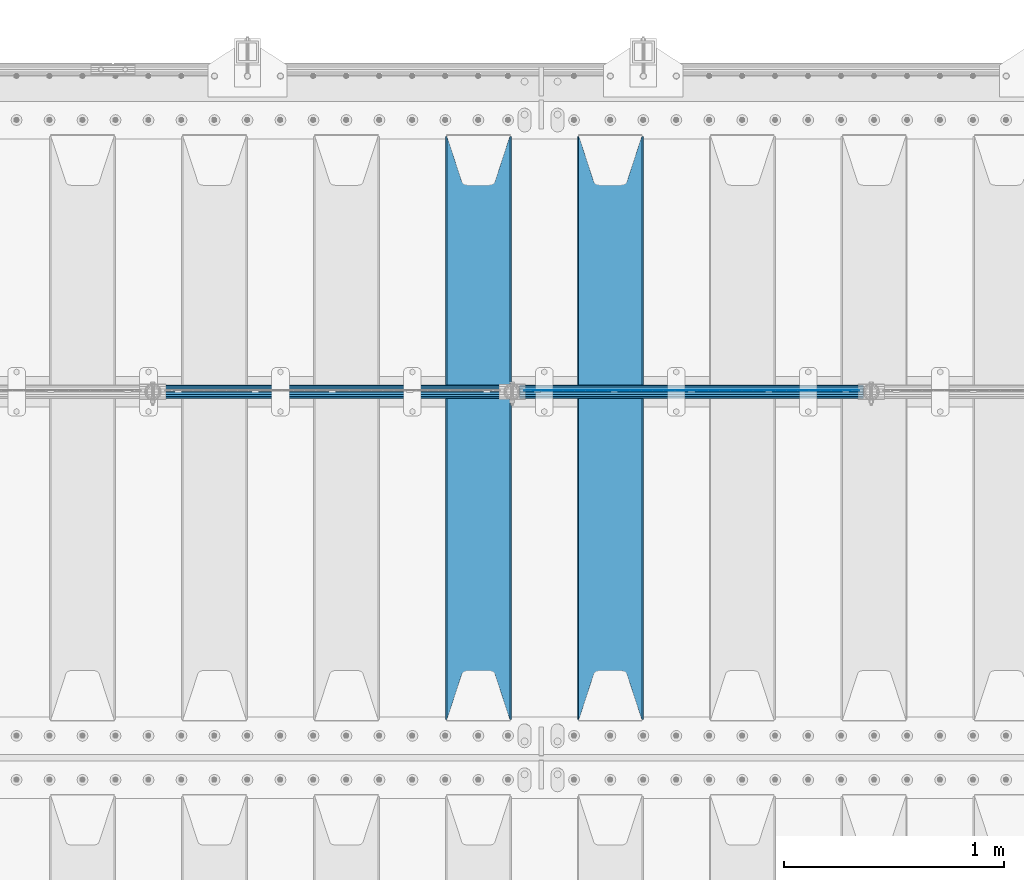
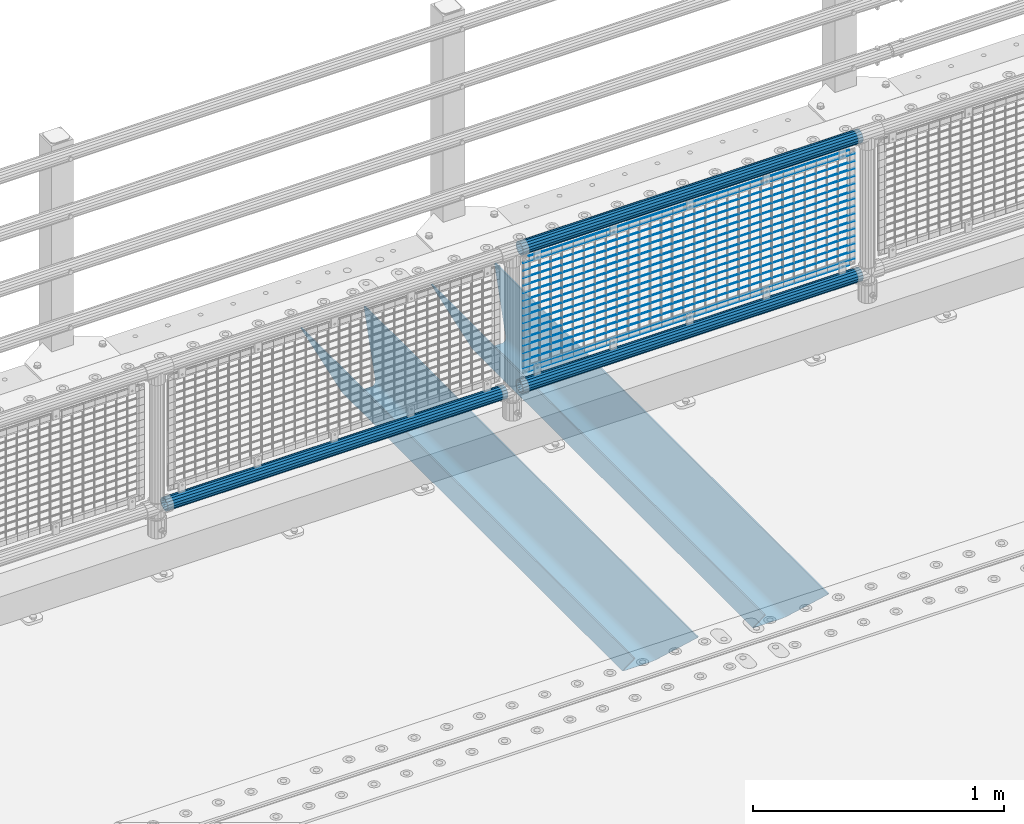
# One storey, part 132 of 270: 22 beams.
"""IFC2X3 building model written with IfcOpenShell, lengths in millimetres."""

from ifc_helpers import new_model, si_unit, frame, origin_with_axes, place, context, subcontext, project, spatial, faceted_brep, material, type_object, element, save


model = new_model("IFC2X3")

# Units and contexts
model_context = context("Model", 3, precision=1e-05, world=origin_with_axes())
body_context = subcontext(model_context, "Body", "Model", "MODEL_VIEW")
ifc_project = project(units=[si_unit("LENGTHUNIT", "METRE", prefix="MILLI"), si_unit("AREAUNIT", "SQUARE_METRE"), si_unit("VOLUMEUNIT", "CUBIC_METRE"), si_unit("MASSUNIT", "GRAM", prefix="KILO"), si_unit("TIMEUNIT", "SECOND"), si_unit("PLANEANGLEUNIT", "RADIAN"), si_unit("SOLIDANGLEUNIT", "STERADIAN"), si_unit("THERMODYNAMICTEMPERATUREUNIT", "DEGREE_CELSIUS"), si_unit("LUMINOUSINTENSITYUNIT", "LUMEN")], contexts=[model_context])

# Site, building, storey
site_placement = place(None, origin_with_axes())
site = spatial("IfcSite", under=ifc_project, at=site_placement, CompositionType="ELEMENT")
building_placement = place(site_placement, origin_with_axes())
building = spatial("IfcBuilding", under=site, at=building_placement, Name="Standard", CompositionType="ELEMENT")
storey_placement = place(building_placement, origin_with_axes())
storey = spatial("IfcBuildingStorey", under=building, at=storey_placement, Name="Undefined", CompositionType="ELEMENT", Elevation=0.0)

# Beams
ifc_material_1 = material(Name="STEEL/S355N")
beam_type_1 = type_object("IfcBeamType", PredefinedType="NOTDEFINED")
beam_1_placement = place(storey_placement, frame((7600.0, -17825.0, -115.0), z_axis=(0.0, 0.0, 1.0), x_axis=(0.0, 1.0, 0.0)))
element("IfcBeam", 1, at=beam_1_placement, inside=storey, type_object=beam_type_1, material=ifc_material_1, context=body_context, shape_type="Brep", body=[
    faceted_brep([(0.0, 150.0, 115.0), (0.0, 143.689999999999, 115.0), (2650.00000000297, 143.689999999999, 115.0), (2650.00000000297, 150.0, 115.0), (2650.00000000297, 142.059565218398, 110.000000003096), (2650.00000000297, 148.3695652184, 110.000000003096), (2441.90079219209, -80.1103600731112, -98.0992078077845), (2437.7588105432, -77.5672621345584, -102.241189456673), (2434.06523489747, -74.4080125315522, -105.934765102404), (2430.9108609509, -70.710272125576, -109.089139048974), (2428.37322971128, -66.5649389910068, -111.626770288588), (2426.51472138055, -62.0739139532889, -113.485278619323), (2425.38102192092, -57.3475956567672, -114.618978078955), (2424.99999999987, -52.5021667386536, -115.0), (2424.99999999987, 52.5021667386536, -115.0), (2425.38102192092, 57.3475956567672, -114.618978078955), (2426.51472138055, 62.0739139532889, -113.485278619323), (2428.37322971128, 66.5649389910068, -111.626770288588), (2430.9108609509, 70.710272125576, -109.089139048974), (2434.06523489747, 74.4080125315522, -105.934765102404), (2437.7588105432, 77.5672621345584, -102.241189456673), (2441.90079219209, 80.1103600731112, -98.0992078077846), (2446.38936140511, 81.9747917625791, -93.6106385947584), (2448.2494850041, 76.2713538057251, -91.7505149957729), (2444.62967112263, 74.76777986261, -95.3703288772456), (2441.28936334126, 72.7168944282894, -98.710636658607), (2438.31067330439, 70.1691124903846, -101.689326695487), (2435.76682334747, 67.1870637758839, -104.233176652398), (2433.72034654133, 63.8440531834895, -106.279653458539), (2432.22154950042, 60.222258798236, -107.778450499454), (2431.30727574265, 56.4107117849089, -108.692724257221), (2430.99999999987, 52.5031078186876, -109.0), (2430.99999999987, -52.5031078186876, -109.0), (2431.30727574265, -56.4107117849089, -108.692724257221), (2432.22154950042, -60.222258798236, -107.778450499454), (2433.72034654133, -63.8440531834895, -106.279653458539), (2435.76682334747, -67.1870637758839, -104.233176652398), (2438.31067330438, -70.1691124903846, -101.689326695487), (2441.28936334126, -72.7168944282894, -98.7106366586071), (2444.62967112263, -74.76777986261, -95.3703288772457), (2448.2494850041, -76.2713538057251, -91.7505149957729), (2650.00000000297, -142.059565218398, 110.000000003096), (2650.00000000297, -148.3695652184, 110.000000003096), (2446.38936140511, -81.9747917625791, -93.6106385947584), (2650.00000000297, -143.689999999999, 115.0), (2650.00000000297, -150.0, 115.0), (0.0, -143.689999999999, 115.0), (0.0, -150.0, 115.0), (0.0, -148.369565218261, 110.000000002672), (203.610638597431, -81.9747917625791, -93.6106385947584), (208.099207810457, -80.1103600731112, -98.0992078077845), (212.241189459342, -77.5672621345584, -102.241189456673), (215.934765105078, -74.4080125315522, -105.934765102404), (219.089139051644, -70.710272125576, -109.089139048974), (221.626770291259, -66.5649389910068, -111.626770288588), (223.485278621993, -62.0739139532889, -113.485278619323), (224.618978081628, -57.3475956567672, -114.618978078955), (225.00000000267, -52.5021667386536, -115.0), (225.00000000267, 52.5021667386536, -115.0), (224.618978081628, 57.3475956567672, -114.618978078955), (223.485278621993, 62.0739139532889, -113.485278619323), (221.626770291259, 66.5649389910068, -111.626770288588), (219.089139051644, 70.710272125576, -109.089139048974), (215.934765105078, 74.4080125315522, -105.934765102404), (212.241189459342, 77.5672621345584, -102.241189456673), (208.099207810457, 80.1103600731112, -98.0992078077846), (203.610638597431, 81.9747917625791, -93.6106385947584), (0.0, 148.369565218261, 110.000000002672), (0.0, 142.05956521826, 110.000000002672), (201.750514998446, 76.2713538057251, -91.7505149957729), (205.370328879915, 74.76777986261, -95.3703288772456), (208.710636661279, 72.7168944282894, -98.710636658607), (211.689326698157, 70.1691124903846, -101.689326695487), (214.233176655071, 67.1870637758839, -104.233176652398), (216.27965346121, 63.8440531834895, -106.279653458539), (217.778450502126, 60.222258798236, -107.778450499454), (218.692724259894, 56.4107117849089, -108.692724257221), (219.00000000267, 52.5031078186876, -109.0), (219.00000000267, -52.5031078186876, -109.0), (218.692724259894, -56.4107117849089, -108.692724257221), (217.778450502123, -60.222258798236, -107.778450499454), (216.27965346121, -63.8440531834895, -106.279653458539), (214.233176655071, -67.1870637758839, -104.233176652398), (211.689326698157, -70.1691124903846, -101.689326695487), (208.710636661279, -72.7168944282894, -98.7106366586071), (205.370328879915, -74.76777986261, -95.3703288772457), (201.750514998446, -76.2713538057251, -91.7505149957729), (0.0, -142.05956521826, 110.000000002672)], [[[0, 1, 2, 3]], [[3, 2, 4, 5]], [[6, 7, 8, 9, 10, 11, 12, 13, 14, 15, 16, 17, 18, 19, 20, 21, 22, 5, 4, 23, 24, 25, 26, 27, 28, 29, 30, 31, 32, 33, 34, 35, 36, 37, 38, 39, 40, 41, 42, 43]], [[44, 45, 42, 41]], [[46, 47, 45, 44]], [[43, 42, 45, 47, 48, 49]], [[6, 43, 49, 50]], [[7, 6, 50, 51]], [[8, 7, 51, 52]], [[9, 8, 52, 53]], [[10, 9, 53, 54]], [[11, 10, 54, 55]], [[12, 11, 55, 56]], [[13, 12, 56, 57]], [[14, 13, 57, 58]], [[15, 14, 58, 59]], [[16, 15, 59, 60]], [[17, 16, 60, 61]], [[18, 17, 61, 62]], [[19, 18, 62, 63]], [[20, 19, 63, 64]], [[21, 20, 64, 65]], [[22, 21, 65, 66]], [[0, 3, 5, 22, 66, 67]], [[1, 0, 67, 68]], [[23, 4, 2, 1, 68, 69]], [[24, 23, 69, 70]], [[25, 24, 70, 71]], [[26, 25, 71, 72]], [[27, 26, 72, 73]], [[28, 27, 73, 74]], [[29, 28, 74, 75]], [[30, 29, 75, 76]], [[31, 30, 76, 77]], [[32, 31, 77, 78]], [[33, 32, 78, 79]], [[34, 33, 79, 80]], [[35, 34, 80, 81]], [[36, 35, 81, 82]], [[37, 36, 82, 83]], [[38, 37, 83, 84]], [[39, 38, 84, 85]], [[40, 39, 85, 86]], [[46, 44, 41, 40, 86, 87]], [[47, 46, 87, 48]], [[86, 85, 84, 83, 82, 81, 80, 79, 78, 77, 76, 75, 74, 73, 72, 71, 70, 69, 68, 67, 66, 65, 64, 63, 62, 61, 60, 59, 58, 57, 56, 55, 54, 53, 52, 51, 50, 49, 48, 87]]]),
])
beam_2_placement = place(storey_placement, frame((7000.0, -17825.0, -115.0), z_axis=(0.0, 0.0, 1.0), x_axis=(0.0, 1.0, 0.0)))
element("IfcBeam", 2, at=beam_2_placement, inside=storey, type_object=beam_type_1, material=ifc_material_1, context=body_context, shape_type="Brep", body=[
    faceted_brep([(0.0, 150.0, 115.0), (0.0, 143.689999999999, 115.0), (2650.00000000297, 143.689999999999, 115.0), (2650.00000000297, 150.0, 115.0), (2650.00000000297, 142.059565218398, 110.000000003096), (2650.00000000297, 148.3695652184, 110.000000003096), (2441.90079219209, -80.1103600731112, -98.0992078077845), (2437.7588105432, -77.5672621345584, -102.241189456673), (2434.06523489747, -74.4080125315522, -105.934765102404), (2430.9108609509, -70.710272125576, -109.089139048974), (2428.37322971128, -66.5649389910068, -111.626770288588), (2426.51472138055, -62.0739139532889, -113.485278619323), (2425.38102192092, -57.3475956567672, -114.618978078955), (2424.99999999987, -52.5021667386536, -115.0), (2424.99999999987, 52.5021667386536, -115.0), (2425.38102192092, 57.3475956567672, -114.618978078955), (2426.51472138055, 62.0739139532889, -113.485278619323), (2428.37322971128, 66.5649389910068, -111.626770288588), (2430.9108609509, 70.710272125576, -109.089139048974), (2434.06523489747, 74.4080125315522, -105.934765102404), (2437.7588105432, 77.5672621345584, -102.241189456673), (2441.90079219209, 80.1103600731112, -98.0992078077846), (2446.38936140511, 81.9747917625791, -93.6106385947584), (2448.2494850041, 76.2713538057251, -91.7505149957729), (2444.62967112263, 74.76777986261, -95.3703288772456), (2441.28936334126, 72.7168944282894, -98.710636658607), (2438.31067330439, 70.1691124903846, -101.689326695487), (2435.76682334747, 67.1870637758839, -104.233176652398), (2433.72034654133, 63.8440531834895, -106.279653458539), (2432.22154950042, 60.222258798236, -107.778450499454), (2431.30727574265, 56.4107117849089, -108.692724257221), (2430.99999999987, 52.5031078186876, -109.0), (2430.99999999987, -52.5031078186876, -109.0), (2431.30727574265, -56.4107117849089, -108.692724257221), (2432.22154950042, -60.222258798236, -107.778450499454), (2433.72034654133, -63.8440531834895, -106.279653458539), (2435.76682334747, -67.1870637758839, -104.233176652398), (2438.31067330438, -70.1691124903846, -101.689326695487), (2441.28936334126, -72.7168944282894, -98.7106366586071), (2444.62967112263, -74.76777986261, -95.3703288772457), (2448.2494850041, -76.2713538057251, -91.7505149957729), (2650.00000000297, -142.059565218398, 110.000000003096), (2650.00000000297, -148.3695652184, 110.000000003096), (2446.38936140511, -81.9747917625791, -93.6106385947584), (2650.00000000297, -143.689999999999, 115.0), (2650.00000000297, -150.0, 115.0), (0.0, -143.689999999999, 115.0), (0.0, -150.0, 115.0), (0.0, -148.369565218261, 110.000000002672), (203.610638597431, -81.9747917625791, -93.6106385947584), (208.099207810457, -80.1103600731112, -98.0992078077845), (212.241189459342, -77.5672621345584, -102.241189456673), (215.934765105078, -74.4080125315522, -105.934765102404), (219.089139051644, -70.710272125576, -109.089139048974), (221.626770291259, -66.5649389910068, -111.626770288588), (223.485278621993, -62.0739139532889, -113.485278619323), (224.618978081628, -57.3475956567672, -114.618978078955), (225.00000000267, -52.5021667386536, -115.0), (225.00000000267, 52.5021667386536, -115.0), (224.618978081628, 57.3475956567672, -114.618978078955), (223.485278621993, 62.0739139532889, -113.485278619323), (221.626770291259, 66.5649389910068, -111.626770288588), (219.089139051644, 70.710272125576, -109.089139048974), (215.934765105078, 74.4080125315522, -105.934765102404), (212.241189459342, 77.5672621345584, -102.241189456673), (208.099207810457, 80.1103600731112, -98.0992078077846), (203.610638597431, 81.9747917625791, -93.6106385947584), (0.0, 148.369565218261, 110.000000002672), (0.0, 142.05956521826, 110.000000002672), (201.750514998446, 76.2713538057251, -91.7505149957729), (205.370328879915, 74.76777986261, -95.3703288772456), (208.710636661279, 72.7168944282894, -98.710636658607), (211.689326698157, 70.1691124903846, -101.689326695487), (214.233176655071, 67.1870637758839, -104.233176652398), (216.27965346121, 63.8440531834895, -106.279653458539), (217.778450502126, 60.222258798236, -107.778450499454), (218.692724259894, 56.4107117849089, -108.692724257221), (219.00000000267, 52.5031078186876, -109.0), (219.00000000267, -52.5031078186876, -109.0), (218.692724259894, -56.4107117849089, -108.692724257221), (217.778450502123, -60.222258798236, -107.778450499454), (216.27965346121, -63.8440531834895, -106.279653458539), (214.233176655071, -67.1870637758839, -104.233176652398), (211.689326698157, -70.1691124903846, -101.689326695487), (208.710636661279, -72.7168944282894, -98.7106366586071), (205.370328879915, -74.76777986261, -95.3703288772457), (201.750514998446, -76.2713538057251, -91.7505149957729), (0.0, -142.05956521826, 110.000000002672)], [[[0, 1, 2, 3]], [[3, 2, 4, 5]], [[6, 7, 8, 9, 10, 11, 12, 13, 14, 15, 16, 17, 18, 19, 20, 21, 22, 5, 4, 23, 24, 25, 26, 27, 28, 29, 30, 31, 32, 33, 34, 35, 36, 37, 38, 39, 40, 41, 42, 43]], [[44, 45, 42, 41]], [[46, 47, 45, 44]], [[43, 42, 45, 47, 48, 49]], [[6, 43, 49, 50]], [[7, 6, 50, 51]], [[8, 7, 51, 52]], [[9, 8, 52, 53]], [[10, 9, 53, 54]], [[11, 10, 54, 55]], [[12, 11, 55, 56]], [[13, 12, 56, 57]], [[14, 13, 57, 58]], [[15, 14, 58, 59]], [[16, 15, 59, 60]], [[17, 16, 60, 61]], [[18, 17, 61, 62]], [[19, 18, 62, 63]], [[20, 19, 63, 64]], [[21, 20, 64, 65]], [[22, 21, 65, 66]], [[0, 3, 5, 22, 66, 67]], [[1, 0, 67, 68]], [[23, 4, 2, 1, 68, 69]], [[24, 23, 69, 70]], [[25, 24, 70, 71]], [[26, 25, 71, 72]], [[27, 26, 72, 73]], [[28, 27, 73, 74]], [[29, 28, 74, 75]], [[30, 29, 75, 76]], [[31, 30, 76, 77]], [[32, 31, 77, 78]], [[33, 32, 78, 79]], [[34, 33, 79, 80]], [[35, 34, 80, 81]], [[36, 35, 81, 82]], [[37, 36, 82, 83]], [[38, 37, 83, 84]], [[39, 38, 84, 85]], [[40, 39, 85, 86]], [[46, 44, 41, 40, 86, 87]], [[47, 46, 87, 48]], [[86, 85, 84, 83, 82, 81, 80, 79, 78, 77, 76, 75, 74, 73, 72, 71, 70, 69, 68, 67, 66, 65, 64, 63, 62, 61, 60, 59, 58, 57, 56, 55, 54, 53, 52, 51, 50, 49, 48, 87]]]),
])
ifc_material_2 = material(Name="Misc_Undefined")
beam_type_2 = type_object("IfcBeamType", Name="D3", PredefinedType="NOTDEFINED")
for number, where, z_axis, x_axis in (
    (3, (7208.0, -16329.5, 851.596999999999), (0.0, 0.0, 1.0), (1.0, 0.0, 0.0)),
    (4, (7208.0, -16329.5, 669.452), (0.0, 0.0, 1.0), (1.0, 0.0, 0.0)),
    (5, (7208.0, -16329.5, 523.736), (0.0, 0.0, 1.0), (1.0, 0.0, 0.0)),
    (6, (7208.0, -16329.5, 487.307), (0.0, 0.0, 1.0), (1.0, 0.0, 0.0)),
    (7, (7208.0, -16329.5, 705.881), (0.0, 0.0, 1.0), (1.0, 0.0, 0.0)),
    (8, (7208.0, -16329.5, 596.594), (0.0, 0.0, 1.0), (1.0, 0.0, 0.0)),
    (9, (7208.0, -16329.5, 450.878), (0.0, 0.0, 1.0), (1.0, 0.0, 0.0)),
    (10, (7208.0, -16329.5, 815.167999999999), (0.0, 0.0, 1.0), (1.0, 0.0, 0.0)),
    (11, (7208.0, -16329.5, 888.025999999999), (0.0, 0.0, 1.0), (1.0, 0.0, 0.0)),
    (12, (7208.0, -16329.5, 778.738999999999), (0.0, 0.0, 1.0), (1.0, 0.0, 0.0)),
    (13, (7208.0, -16329.5, 742.309999999999), (0.0, 0.0, 1.0), (1.0, 0.0, 0.0)),
    (14, (7208.0, -16329.5, 633.023), (0.0, 0.0, 1.0), (1.0, 0.0, 0.0)),
    (15, (7208.0, -16329.5, 560.165), (0.0, 0.0, 1.0), (1.0, 0.0, 0.0)),
    (16, (7208.0, -16329.5, 414.449), (0.0, 0.0, 1.0), (1.0, 0.0, 0.0)),
):
    element("IfcBeam", number, at=place(storey_placement, frame(where, z_axis=z_axis, x_axis=x_axis)), inside=storey, type_object=beam_type_2, material=ifc_material_2, ObjectType="D3", context=body_context, shape_type="Brep", body=[
        faceted_brep([(0.0, -1.5, 0.0), (0.0, -0.75, -1.29903810567669), (1523.0, -0.75, -1.29903810567669), (1523.0, -1.5, 0.0), (0.0, 0.75, -1.29903810567669), (1523.0, 0.75, -1.29903810567669), (0.0, 1.5, 0.0), (1523.0, 1.5, 0.0), (0.0, 0.75, 1.29903810567669), (1523.0, 0.75, 1.29903810567669), (0.0, -0.75, 1.29903810567669), (1523.0, -0.75, 1.29903810567669)], [[[0, 1, 2, 3]], [[1, 4, 5, 2]], [[4, 6, 7, 5]], [[6, 8, 9, 7]], [[8, 10, 11, 9]], [[10, 0, 3, 11]], [[5, 7, 9, 11, 3, 2]], [[10, 8, 6, 4, 1, 0]]]),
    ])
beam_3_placement = place(storey_placement, frame((7233.0, -16329.5, 353.02), z_axis=(0.0, 0.0, 1.0), x_axis=(1.0, 0.0, 0.0)))
element("IfcBeam", 17, at=beam_3_placement, inside=storey, type_object=beam_type_2, material=ifc_material_2, ObjectType="D3", context=body_context, shape_type="Brep", body=[
    faceted_brep([(0.0, -1.5, 0.0), (0.0, -0.75, -1.29903810567669), (1473.0, -0.75, -1.29903810567669), (1473.0, -1.5, 0.0), (0.0, 0.75, -1.29903810567669), (1473.0, 0.75, -1.29903810567663), (0.0, 1.5, 0.0), (1473.0, 1.5, 0.0), (0.0, 0.75, 1.29903810567669), (1473.0, 0.75, 1.29903810567669), (0.0, -0.75, 1.29903810567669), (1473.0, -0.75, 1.29903810567669)], [[[0, 1, 2, 3]], [[1, 4, 5, 2]], [[4, 6, 7, 5]], [[6, 8, 9, 7]], [[8, 10, 11, 9]], [[10, 0, 3, 11]], [[5, 7, 9, 11, 3, 2]], [[10, 8, 6, 4, 1, 0]]]),
])
beam_4_placement = place(storey_placement, frame((7208.0, -16329.5, 378.02), z_axis=(0.0, 0.0, 1.0), x_axis=(1.0, 0.0, 0.0)))
element("IfcBeam", 18, at=beam_4_placement, inside=storey, type_object=beam_type_2, material=ifc_material_2, ObjectType="D3", context=body_context, shape_type="Brep", body=[
    faceted_brep([(0.0, -1.5, 0.0), (0.0, -0.75, -1.29903810567669), (1523.0, -0.75, -1.29903810567669), (1523.0, -1.5, 0.0), (0.0, 0.75, -1.29903810567669), (1523.0, 0.75, -1.29903810567669), (0.0, 1.5, 0.0), (1523.0, 1.5, 0.0), (0.0, 0.75, 1.29903810567669), (1523.0, 0.75, 1.29903810567669), (0.0, -0.75, 1.29903810567669), (1523.0, -0.75, 1.29903810567669)], [[[0, 1, 2, 3]], [[1, 4, 5, 2]], [[4, 6, 7, 5]], [[6, 8, 9, 7]], [[8, 10, 11, 9]], [[10, 0, 3, 11]], [[5, 7, 9, 11, 3, 2]], [[10, 8, 6, 4, 1, 0]]]),
])
beam_5_placement = place(storey_placement, frame((7233.0, -16329.5, 913.02), z_axis=(0.0, 0.0, 1.0), x_axis=(1.0, 0.0, 0.0)))
element("IfcBeam", 19, at=beam_5_placement, inside=storey, type_object=beam_type_2, material=ifc_material_2, ObjectType="D3", context=body_context, shape_type="Brep", body=[
    faceted_brep([(0.0, -1.5, 0.0), (0.0, -0.75, -1.29903810567669), (1473.0, -0.75, -1.29903810567669), (1473.0, -1.5, 0.0), (0.0, 0.75, -1.29903810567669), (1473.0, 0.75, -1.29903810567663), (0.0, 1.5, 0.0), (1473.0, 1.5, 0.0), (0.0, 0.75, 1.29903810567669), (1473.0, 0.75, 1.29903810567669), (0.0, -0.75, 1.29903810567669), (1473.0, -0.75, 1.29903810567669)], [[[0, 1, 2, 3]], [[1, 4, 5, 2]], [[4, 6, 7, 5]], [[6, 8, 9, 7]], [[8, 10, 11, 9]], [[10, 0, 3, 11]], [[5, 7, 9, 11, 3, 2]], [[10, 8, 6, 4, 1, 0]]]),
])
ifc_material_3 = material()
beam_type_3 = type_object("IfcBeamType", PredefinedType="NOTDEFINED")
beam_6_placement = place(storey_placement, frame((7187.85, -16335.5, 969.849999999999), z_axis=(0.0, 0.0, 1.0), x_axis=(1.0, 0.0, 0.0)))
element("IfcBeam", 20, at=beam_6_placement, inside=storey, type_object=beam_type_3, material=ifc_material_3, context=body_context, shape_type="Brep", body=[
    faceted_brep([(0.0, -25.3500000000004, 0.0), (0.0, -23.4203461491616, 9.70102501045403), (1563.0, -23.4203461491616, 9.70102501045506), (1563.0, -25.3500000000004, 0.0), (0.0, -17.9251569030785, 17.9251569030785), (1563.0, -17.9251569030785, 17.925156903079), (0.0, -9.70102501045585, 23.4203461491597), (1563.0, -9.70102501045585, 23.4203461491611), (0.0, 0.0, 25.3499999999985), (1563.0, 0.0, 25.35), (0.0, 9.70102501045585, 23.4203461491597), (1563.0, 9.70102501045585, 23.4203461491611), (0.0, 17.9251569030785, 17.9251569030785), (1563.0, 17.9251569030785, 17.925156903079), (0.0, 23.4203461491616, 9.70102501045403), (1563.0, 23.4203461491616, 9.70102501045506), (0.0, 25.3500000000004, 0.0), (1563.0, 25.3500000000004, 0.0), (0.0, 23.4203461491616, -9.70102501045403), (1563.0, 23.4203461491616, -9.70102501045506), (0.0, 17.9251569030785, -17.9251569030785), (1563.0, 17.9251569030785, -17.925156903079), (0.0, 9.70102501045585, -23.4203461491597), (1563.0, 9.70102501045585, -23.4203461491611), (0.0, 0.0, -25.3499999999985), (1563.0, 0.0, -25.35), (0.0, -9.70102501045585, -23.4203461491597), (1563.0, -9.70102501045585, -23.4203461491611), (0.0, -17.9251569030785, -17.9251569030785), (1563.0, -17.9251569030785, -17.925156903079), (0.0, -23.4203461491616, -9.70102501045403), (1563.0, -23.4203461491616, -9.70102501045506), (0.0, -30.1499999999996, 0.0), (0.0, -27.8549679052157, -11.5379054858058), (1563.0, -27.8549679052157, -11.5379054858075), (1563.0, -30.1499999999996, 0.0), (0.0, -21.3192694527752, -21.3192694527752), (1563.0, -21.3192694527752, -21.3192694527744), (0.0, -11.5379054858076, -27.8549679052157), (1563.0, -11.5379054858076, -27.8549679052153), (0.0, 0.0, -30.1500000000015), (1563.0, 0.0, -30.15), (0.0, 11.5379054858076, -27.8549679052157), (1563.0, 11.5379054858076, -27.8549679052153), (0.0, 21.3192694527752, -21.3192694527752), (1563.0, 21.3192694527752, -21.3192694527744), (0.0, 27.8549679052157, -11.5379054858058), (1563.0, 27.8549679052157, -11.5379054858074), (0.0, 30.1499999999996, 0.0), (1563.0, 30.1499999999996, 0.0), (0.0, 27.8549679052157, 11.5379054858058), (1563.0, 27.8549679052157, 11.5379054858074), (0.0, 21.3192694527752, 21.3192694527752), (1563.0, 21.3192694527752, 21.3192694527744), (0.0, 11.5379054858076, 27.8549679052157), (1563.0, 11.5379054858076, 27.8549679052153), (0.0, 0.0, 30.1500000000015), (1563.0, 0.0, 30.15), (0.0, -11.5379054858076, 27.8549679052157), (1563.0, -11.5379054858076, 27.8549679052153), (0.0, -21.3192694527752, 21.3192694527752), (1563.0, -21.3192694527752, 21.3192694527744), (0.0, -27.8549679052157, 11.5379054858058), (1563.0, -27.8549679052157, 11.5379054858074)], [[[0, 1, 2, 3]], [[1, 4, 5, 2]], [[4, 6, 7, 5]], [[6, 8, 9, 7]], [[8, 10, 11, 9]], [[10, 12, 13, 11]], [[12, 14, 15, 13]], [[14, 16, 17, 15]], [[16, 18, 19, 17]], [[18, 20, 21, 19]], [[20, 22, 23, 21]], [[22, 24, 25, 23]], [[24, 26, 27, 25]], [[26, 28, 29, 27]], [[28, 30, 31, 29]], [[30, 0, 3, 31]], [[32, 33, 34, 35]], [[33, 36, 37, 34]], [[36, 38, 39, 37]], [[38, 40, 41, 39]], [[40, 42, 43, 41]], [[42, 44, 45, 43]], [[44, 46, 47, 45]], [[46, 48, 49, 47]], [[48, 50, 51, 49]], [[50, 52, 53, 51]], [[52, 54, 55, 53]], [[54, 56, 57, 55]], [[56, 58, 59, 57]], [[58, 60, 61, 59]], [[60, 62, 63, 61]], [[62, 32, 35, 63]], [[37, 39, 41, 43, 45, 47, 49, 51, 53, 55, 57, 59, 61, 63, 35, 34], [5, 7, 9, 11, 13, 15, 17, 19, 21, 23, 25, 27, 29, 31, 3, 2]], [[62, 60, 58, 56, 54, 52, 50, 48, 46, 44, 42, 40, 38, 36, 33, 32], [30, 28, 26, 24, 22, 20, 18, 16, 14, 12, 10, 8, 6, 4, 1, 0]]]),
])
beam_7_placement = place(storey_placement, frame((7187.85000000001, -16335.5, 298.170000000001), z_axis=(0.0, 0.0, 1.0), x_axis=(1.0, 0.0, 0.0)))
element("IfcBeam", 21, at=beam_7_placement, inside=storey, type_object=beam_type_3, material=ifc_material_3, context=body_context, shape_type="Brep", body=[
    faceted_brep([(0.0, -25.3500000000004, 0.0), (0.0, -23.4203461491616, 9.70102501045403), (1563.0, -23.4203461491616, 9.70102501045506), (1563.0, -25.3500000000004, 0.0), (0.0, -17.9251569030785, 17.9251569030785), (1563.0, -17.9251569030785, 17.925156903079), (0.0, -9.70102501045585, 23.4203461491597), (1563.0, -9.70102501045585, 23.4203461491611), (0.0, 0.0, 25.3499999999985), (1563.0, 0.0, 25.35), (0.0, 9.70102501045585, 23.4203461491597), (1563.0, 9.70102501045585, 23.4203461491611), (0.0, 17.9251569030785, 17.9251569030785), (1563.0, 17.9251569030785, 17.925156903079), (0.0, 23.4203461491616, 9.70102501045403), (1563.0, 23.4203461491616, 9.70102501045506), (0.0, 25.3500000000004, 0.0), (1563.0, 25.3500000000004, 0.0), (0.0, 23.4203461491616, -9.70102501045403), (1563.0, 23.4203461491616, -9.70102501045506), (0.0, 17.9251569030785, -17.9251569030785), (1563.0, 17.9251569030785, -17.925156903079), (0.0, 9.70102501045585, -23.4203461491597), (1563.0, 9.70102501045585, -23.4203461491611), (0.0, 0.0, -25.3499999999985), (1563.0, 0.0, -25.35), (0.0, -9.70102501045585, -23.4203461491597), (1563.0, -9.70102501045585, -23.4203461491611), (0.0, -17.9251569030785, -17.9251569030785), (1563.0, -17.9251569030785, -17.925156903079), (0.0, -23.4203461491616, -9.70102501045403), (1563.0, -23.4203461491616, -9.70102501045506), (0.0, -30.1499999999996, 0.0), (0.0, -27.8549679052157, -11.5379054858058), (1563.0, -27.8549679052157, -11.5379054858075), (1563.0, -30.1499999999996, 0.0), (0.0, -21.3192694527752, -21.3192694527752), (1563.0, -21.3192694527752, -21.3192694527744), (0.0, -11.5379054858076, -27.8549679052157), (1563.0, -11.5379054858076, -27.8549679052153), (0.0, 0.0, -30.1500000000015), (1563.0, 0.0, -30.15), (0.0, 11.5379054858076, -27.8549679052157), (1563.0, 11.5379054858076, -27.8549679052153), (0.0, 21.3192694527752, -21.3192694527752), (1563.0, 21.3192694527752, -21.3192694527744), (0.0, 27.8549679052157, -11.5379054858058), (1563.0, 27.8549679052157, -11.5379054858074), (0.0, 30.1499999999996, 0.0), (1563.0, 30.1499999999996, 0.0), (0.0, 27.8549679052157, 11.5379054858058), (1563.0, 27.8549679052157, 11.5379054858074), (0.0, 21.3192694527752, 21.3192694527752), (1563.0, 21.3192694527752, 21.3192694527744), (0.0, 11.5379054858076, 27.8549679052157), (1563.0, 11.5379054858076, 27.8549679052153), (0.0, 0.0, 30.1500000000015), (1563.0, 0.0, 30.15), (0.0, -11.5379054858076, 27.8549679052157), (1563.0, -11.5379054858076, 27.8549679052153), (0.0, -21.3192694527752, 21.3192694527752), (1563.0, -21.3192694527752, 21.3192694527744), (0.0, -27.8549679052157, 11.5379054858058), (1563.0, -27.8549679052157, 11.5379054858074)], [[[0, 1, 2, 3]], [[1, 4, 5, 2]], [[4, 6, 7, 5]], [[6, 8, 9, 7]], [[8, 10, 11, 9]], [[10, 12, 13, 11]], [[12, 14, 15, 13]], [[14, 16, 17, 15]], [[16, 18, 19, 17]], [[18, 20, 21, 19]], [[20, 22, 23, 21]], [[22, 24, 25, 23]], [[24, 26, 27, 25]], [[26, 28, 29, 27]], [[28, 30, 31, 29]], [[30, 0, 3, 31]], [[32, 33, 34, 35]], [[33, 36, 37, 34]], [[36, 38, 39, 37]], [[38, 40, 41, 39]], [[40, 42, 43, 41]], [[42, 44, 45, 43]], [[44, 46, 47, 45]], [[46, 48, 49, 47]], [[48, 50, 51, 49]], [[50, 52, 53, 51]], [[52, 54, 55, 53]], [[54, 56, 57, 55]], [[56, 58, 59, 57]], [[58, 60, 61, 59]], [[60, 62, 63, 61]], [[62, 32, 35, 63]], [[37, 39, 41, 43, 45, 47, 49, 51, 53, 55, 57, 59, 61, 63, 35, 34], [5, 7, 9, 11, 13, 15, 17, 19, 21, 23, 25, 27, 29, 31, 3, 2]], [[62, 60, 58, 56, 54, 52, 50, 48, 46, 44, 42, 40, 38, 36, 33, 32], [30, 28, 26, 24, 22, 20, 18, 16, 14, 12, 10, 8, 6, 4, 1, 0]]]),
])
beam_8_placement = place(storey_placement, frame((5554.85000000001, -16335.5, 298.170000000001), z_axis=(0.0, 0.0, 1.0), x_axis=(1.0, 0.0, 0.0)))
element("IfcBeam", 22, at=beam_8_placement, inside=storey, type_object=beam_type_3, material=ifc_material_3, context=body_context, shape_type="Brep", body=[
    faceted_brep([(0.0, -25.3500000000004, 0.0), (0.0, -23.4203461491616, 9.70102501045403), (1563.0, -23.4203461491616, 9.70102501045506), (1563.0, -25.3500000000004, 0.0), (0.0, -17.9251569030785, 17.9251569030785), (1563.0, -17.9251569030785, 17.925156903079), (0.0, -9.70102501045585, 23.4203461491597), (1563.0, -9.70102501045585, 23.4203461491611), (0.0, 0.0, 25.3499999999985), (1563.0, 0.0, 25.35), (0.0, 9.70102501045585, 23.4203461491597), (1563.0, 9.70102501045585, 23.4203461491611), (0.0, 17.9251569030785, 17.9251569030785), (1563.0, 17.9251569030785, 17.925156903079), (0.0, 23.4203461491616, 9.70102501045403), (1563.0, 23.4203461491616, 9.70102501045506), (0.0, 25.3500000000004, 0.0), (1563.0, 25.3500000000004, 0.0), (0.0, 23.4203461491616, -9.70102501045403), (1563.0, 23.4203461491616, -9.70102501045506), (0.0, 17.9251569030785, -17.9251569030785), (1563.0, 17.9251569030785, -17.925156903079), (0.0, 9.70102501045585, -23.4203461491597), (1563.0, 9.70102501045585, -23.4203461491611), (0.0, 0.0, -25.3499999999985), (1563.0, 0.0, -25.35), (0.0, -9.70102501045585, -23.4203461491597), (1563.0, -9.70102501045585, -23.4203461491611), (0.0, -17.9251569030785, -17.9251569030785), (1563.0, -17.9251569030785, -17.925156903079), (0.0, -23.4203461491616, -9.70102501045403), (1563.0, -23.4203461491616, -9.70102501045506), (0.0, -30.1499999999996, 0.0), (0.0, -27.8549679052157, -11.5379054858058), (1563.0, -27.8549679052157, -11.5379054858075), (1563.0, -30.1499999999996, 0.0), (0.0, -21.3192694527752, -21.3192694527752), (1563.0, -21.3192694527752, -21.3192694527744), (0.0, -11.5379054858076, -27.8549679052157), (1563.0, -11.5379054858076, -27.8549679052153), (0.0, 0.0, -30.1500000000015), (1563.0, 0.0, -30.15), (0.0, 11.5379054858076, -27.8549679052157), (1563.0, 11.5379054858076, -27.8549679052153), (0.0, 21.3192694527752, -21.3192694527752), (1563.0, 21.3192694527752, -21.3192694527744), (0.0, 27.8549679052157, -11.5379054858058), (1563.0, 27.8549679052157, -11.5379054858074), (0.0, 30.1499999999996, 0.0), (1563.0, 30.1499999999996, 0.0), (0.0, 27.8549679052157, 11.5379054858058), (1563.0, 27.8549679052157, 11.5379054858074), (0.0, 21.3192694527752, 21.3192694527752), (1563.0, 21.3192694527752, 21.3192694527744), (0.0, 11.5379054858076, 27.8549679052157), (1563.0, 11.5379054858076, 27.8549679052153), (0.0, 0.0, 30.1500000000015), (1563.0, 0.0, 30.15), (0.0, -11.5379054858076, 27.8549679052157), (1563.0, -11.5379054858076, 27.8549679052153), (0.0, -21.3192694527752, 21.3192694527752), (1563.0, -21.3192694527752, 21.3192694527744), (0.0, -27.8549679052157, 11.5379054858058), (1563.0, -27.8549679052157, 11.5379054858074)], [[[0, 1, 2, 3]], [[1, 4, 5, 2]], [[4, 6, 7, 5]], [[6, 8, 9, 7]], [[8, 10, 11, 9]], [[10, 12, 13, 11]], [[12, 14, 15, 13]], [[14, 16, 17, 15]], [[16, 18, 19, 17]], [[18, 20, 21, 19]], [[20, 22, 23, 21]], [[22, 24, 25, 23]], [[24, 26, 27, 25]], [[26, 28, 29, 27]], [[28, 30, 31, 29]], [[30, 0, 3, 31]], [[32, 33, 34, 35]], [[33, 36, 37, 34]], [[36, 38, 39, 37]], [[38, 40, 41, 39]], [[40, 42, 43, 41]], [[42, 44, 45, 43]], [[44, 46, 47, 45]], [[46, 48, 49, 47]], [[48, 50, 51, 49]], [[50, 52, 53, 51]], [[52, 54, 55, 53]], [[54, 56, 57, 55]], [[56, 58, 59, 57]], [[58, 60, 61, 59]], [[60, 62, 63, 61]], [[62, 32, 35, 63]], [[37, 39, 41, 43, 45, 47, 49, 51, 53, 55, 57, 59, 61, 63, 35, 34], [5, 7, 9, 11, 13, 15, 17, 19, 21, 23, 25, 27, 29, 31, 3, 2]], [[62, 60, 58, 56, 54, 52, 50, 48, 46, 44, 42, 40, 38, 36, 33, 32], [30, 28, 26, 24, 22, 20, 18, 16, 14, 12, 10, 8, 6, 4, 1, 0]]]),
])

save(model, "model.ifc")
